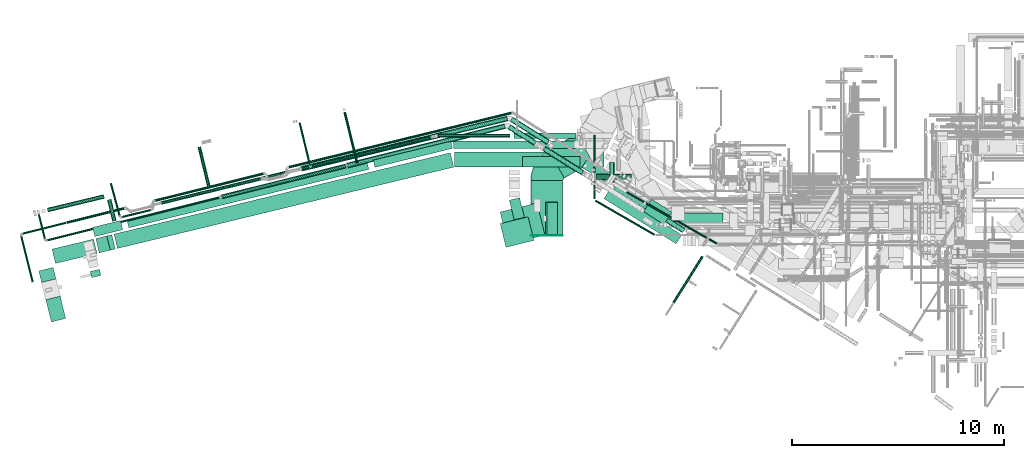
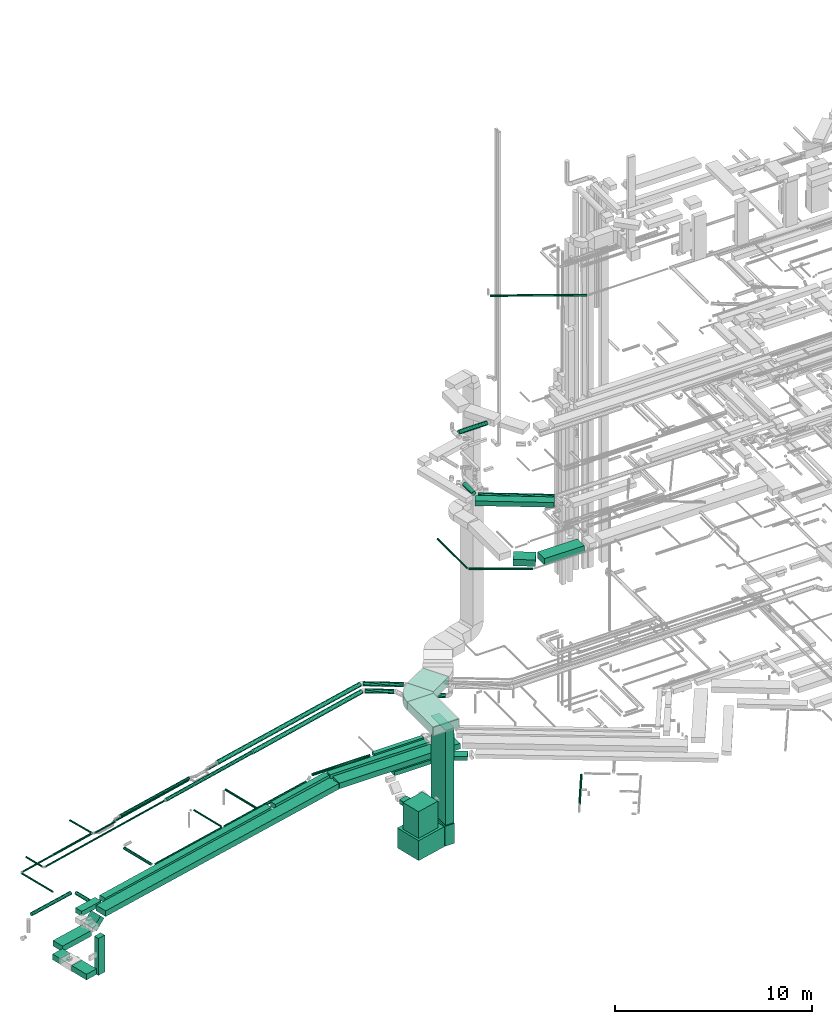
# One storey, part 22 of 337: 55 flow segments, 4 flow fittings.
"""IFC2X3 building model written with IfcOpenShell, lengths in millimetres."""

from ifc_helpers import new_model, entity, si_unit, converted_unit, derived_unit, direction, frame, frame_2d, origin, origin_2d_with_axis, place, context, subcontext, project, spatial, polyline, circle_curve, parameter, trimmed, segment, composite_curve, rectangle, circle, outline, extrude, source, transform, mapped, material, type_object, type_shapes, element, save


model = new_model("IFC2X3")

# Units and contexts
model_context = context("Model", 3, precision=0.01, world=origin(), true_north=direction((6.12303176911189e-17, 1.0)))
body_context = subcontext(model_context, "Body", "Model", "MODEL_VIEW")
ifc_project = project(units=[si_unit("LENGTHUNIT", "METRE", prefix="MILLI"), si_unit("AREAUNIT", "SQUARE_METRE"), si_unit("VOLUMEUNIT", "CUBIC_METRE"), converted_unit("PLANEANGLEUNIT", "DEGREE", entity("IfcRatioMeasure", 0.0174532925199433), si_unit("PLANEANGLEUNIT", "RADIAN"), dimensions=[0, 0, 0, 0, 0, 0, 0]), si_unit("MASSUNIT", "GRAM", prefix="KILO"), derived_unit("MASSDENSITYUNIT", [(si_unit("MASSUNIT", "GRAM", prefix="KILO"), 1), (si_unit("LENGTHUNIT", "METRE"), -3)]), derived_unit("MOMENTOFINERTIAUNIT", [(si_unit("LENGTHUNIT", "METRE"), 4)]), si_unit("TIMEUNIT", "SECOND"), si_unit("FREQUENCYUNIT", "HERTZ"), si_unit("THERMODYNAMICTEMPERATUREUNIT", "DEGREE_CELSIUS"), derived_unit("THERMALTRANSMITTANCEUNIT", [(si_unit("MASSUNIT", "GRAM", prefix="KILO"), 1), (si_unit("THERMODYNAMICTEMPERATUREUNIT", "KELVIN"), -1), (si_unit("TIMEUNIT", "SECOND"), -3)]), derived_unit("VOLUMETRICFLOWRATEUNIT", [(si_unit("LENGTHUNIT", "METRE"), 3), (si_unit("TIMEUNIT", "SECOND"), -1)]), derived_unit("MASSFLOWRATEUNIT", [(si_unit("MASSUNIT", "GRAM", prefix="KILO"), 1), (si_unit("TIMEUNIT", "SECOND"), -1)]), derived_unit("ROTATIONALFREQUENCYUNIT", [(si_unit("TIMEUNIT", "SECOND"), -1)]), si_unit("ELECTRICCURRENTUNIT", "AMPERE"), si_unit("ELECTRICVOLTAGEUNIT", "VOLT"), si_unit("POWERUNIT", "WATT"), si_unit("FORCEUNIT", "NEWTON", prefix="KILO"), si_unit("ILLUMINANCEUNIT", "LUX"), si_unit("LUMINOUSFLUXUNIT", "LUMEN"), si_unit("LUMINOUSINTENSITYUNIT", "CANDELA"), derived_unit("USERDEFINED", [(si_unit("MASSUNIT", "GRAM", prefix="KILO"), -1), (si_unit("LENGTHUNIT", "METRE"), -2), (si_unit("TIMEUNIT", "SECOND"), 3), (si_unit("LUMINOUSFLUXUNIT", "LUMEN"), 1)]), derived_unit("LINEARVELOCITYUNIT", [(si_unit("LENGTHUNIT", "METRE"), 1), (si_unit("TIMEUNIT", "SECOND"), -1)]), si_unit("PRESSUREUNIT", "PASCAL"), derived_unit("USERDEFINED", [(si_unit("LENGTHUNIT", "METRE"), -2), (si_unit("MASSUNIT", "GRAM", prefix="KILO"), 1), (si_unit("TIMEUNIT", "SECOND"), -2)]), derived_unit("LINEARFORCEUNIT", [(si_unit("MASSUNIT", "GRAM", prefix="KILO"), 1), (si_unit("LENGTHUNIT", "METRE"), 1), (si_unit("TIMEUNIT", "SECOND"), -2), (si_unit("LENGTHUNIT", "METRE"), -1)]), derived_unit("PLANARFORCEUNIT", [(si_unit("MASSUNIT", "GRAM", prefix="KILO"), 1), (si_unit("LENGTHUNIT", "METRE"), 1), (si_unit("TIMEUNIT", "SECOND"), -2), (si_unit("LENGTHUNIT", "METRE"), -2)])], contexts=[model_context])

# Site, building, storey
site_placement = place(None, origin())
site = spatial("IfcSite", under=ifc_project, at=site_placement, CompositionType="ELEMENT")
building_placement = place(site_placement, origin())
building = spatial("IfcBuilding", under=site, at=building_placement, CompositionType="ELEMENT")
storey_placement = place(building_placement, origin())
storey = spatial("IfcBuildingStorey", under=building, at=storey_placement, CompositionType="ELEMENT", Elevation=0.0)

# Flow segments
duct_segment_type_1 = type_object("IfcDuctSegmentType", PredefinedType="NOTDEFINED")
flow_segment_1_placement = place(storey_placement, frame((-24658.62, 6458.64, -1525.0)))
element("IfcFlowSegment", 1, at=flow_segment_1_placement, inside=storey, type_object=duct_segment_type_1, context=body_context, shape_type="SweptSolid", body=[
    extrude(rectangle(XDim=1079.40182496234, YDim=700.000000000001, at=origin_2d_with_axis()), frame((468.95, 607.76, 0.0), z_axis=(0.0, 0.0, 1.0), x_axis=(-0.239234929345687, 0.970961713241549, 0.0)), (0.0, 0.0, 1.0), 350.0),
])
flow_segment_2_placement = place(storey_placement, frame((-24994.78, 8323.76, -1525.0)))
element("IfcFlowSegment", 2, at=flow_segment_2_placement, inside=storey, type_object=duct_segment_type_1, context=body_context, shape_type="SweptSolid", body=[
    extrude(rectangle(XDim=563.648083324207, YDim=699.999999999999, at=origin_2d_with_axis()), frame((407.26, 357.37, 0.0), z_axis=(0.0, 0.0, 1.0), x_axis=(-0.239240175396018, 0.970960420653943, 0.0)), (0.0, 0.0, 1.0), 350.0),
])
flow_segment_3_placement = place(storey_placement, frame((-21439.78, 9928.88, -800.0)))
element("IfcFlowSegment", 3, at=flow_segment_3_placement, inside=storey, type_object=duct_segment_type_1, context=body_context, shape_type="SweptSolid", body=[
    extrude(rectangle(XDim=16341.481014958, YDim=699.999999999999, at=origin_2d_with_axis()), frame((8023.96, 2261.37, 0.0), z_axis=(0.0, 0.0, 1.0), x_axis=(0.971963923974013, 0.235130028905367, 0.0)), (0.0, 0.0, 1.0), 350.0),
])
flow_segment_4_placement = place(storey_placement, frame((-5356.59, 13775.46, -800.0)))
element("IfcFlowSegment", 4, at=flow_segment_4_placement, inside=storey, type_object=duct_segment_type_1, context=body_context, shape_type="SweptSolid", body=[
    extrude(rectangle(XDim=7058.84355228445, YDim=700.000000000001, at=origin_2d_with_axis()), frame((3529.42, 350.0, 0.0), z_axis=(0.0, 0.0, 1.0), x_axis=(-1.0, 0.0, 0.0)), (0.0, 0.0, 1.0), 350.0),
])
flow_segment_5_placement = place(storey_placement, frame((-3207.37, 10132.86, -3924.0)))
element("IfcFlowSegment", 5, at=flow_segment_5_placement, inside=storey, type_object=duct_segment_type_1, context=body_context, shape_type="SweptSolid", body=[
    extrude(rectangle(XDim=1798.03044704214, YDim=1568.0, at=origin_2d_with_axis()), frame((1059.56, 975.17, 0.0), z_axis=(0.0, 0.0, 1.0), x_axis=(0.971358698487876, 0.237617926242823, 0.0)), (0.0, 0.0, 1.0), 1238.0),
])
flow_segment_6_placement = place(storey_placement, frame((-1052.61, 10564.4, -3924.0)))
element("IfcFlowSegment", 6, at=flow_segment_6_placement, inside=storey, type_object=duct_segment_type_1, context=body_context, shape_type="SweptSolid", body=[
    extrude(rectangle(XDim=567.420212627502, YDim=1568.0, at=origin_2d_with_axis()), frame((283.71, 784.0, 0.0)), (0.0, 0.0, 1.0), 1238.0),
])
flow_segment_7_placement = place(storey_placement, frame((-22566.41, 8552.28, -3185.0)))
element("IfcFlowSegment", 7, at=flow_segment_7_placement, inside=storey, type_object=duct_segment_type_1, context=body_context, shape_type="SweptSolid", body=[
    extrude(rectangle(XDim=300.000000000002, YDim=450.000000000001, at=origin_2d_with_axis()), frame((254.08, 198.94, 0.0), z_axis=(1.30834769717266e-06, -5.37909916892362e-06, 1.0), x_axis=(-0.236337623155953, 0.97167099774067, 5.5359264415102e-06)), (0.0, 0.0, 1.0), 2284.95162721462),
])
flow_segment_8_placement = place(storey_placement, frame((-20835.17, 10902.27, -750.0)))
element("IfcFlowSegment", 8, at=flow_segment_8_placement, inside=storey, type_object=duct_segment_type_1, context=body_context, shape_type="SweptSolid", body=[
    extrude(rectangle(XDim=11666.6777760886, YDim=399.999999999999, at=origin_2d_with_axis()), frame((5714.8, 1575.61, 0.0), z_axis=(0.0, 0.0, 1.0), x_axis=(0.971559912665503, 0.236793868377963, 0.0)), (0.0, 0.0, 1.0), 300.0),
])
flow_segment_9_placement = place(storey_placement, frame((-9202.9, 13760.19, -750.0)))
element("IfcFlowSegment", 9, at=flow_segment_9_placement, inside=storey, type_object=duct_segment_type_1, context=body_context, shape_type="SweptSolid", body=[
    extrude(rectangle(XDim=3774.44741521228, YDim=350.0, at=origin_2d_with_axis()), frame((1874.99, 616.91, 0.0), z_axis=(0.0, 0.0, 1.0), x_axis=(0.9715599126655, 0.236793868377977, 0.0)), (0.0, 0.0, 1.0), 300.0),
])
flow_segment_10_placement = place(storey_placement, frame((-5417.41, 14658.23, -750.0)))
element("IfcFlowSegment", 10, at=flow_segment_10_placement, inside=storey, type_object=duct_segment_type_1, context=body_context, shape_type="SweptSolid", body=[
    extrude(rectangle(XDim=5802.50714283817, YDim=350.000000000001, at=origin_2d_with_axis()), frame((2901.25, 175.0, 0.0), z_axis=(0.0, 0.0, 1.0), x_axis=(-1.0, 0.0, 0.0)), (0.0, 0.0, 1.0), 300.0),
])
flow_segment_11_placement = place(storey_placement, frame((-22455.84, 10491.91, -750.0)))
element("IfcFlowSegment", 11, at=flow_segment_11_placement, inside=storey, type_object=duct_segment_type_1, context=body_context, shape_type="SweptSolid", body=[
    extrude(rectangle(XDim=1360.43438674366, YDim=450.0, at=origin_2d_with_axis()), frame((714.09, 379.09, 0.0), z_axis=(0.0, 0.0, 1.0), x_axis=(-0.971787577071847, -0.235857806843082, 0.0)), (0.0, 0.0, 1.0), 300.0),
])
flow_segment_12_placement = place(storey_placement, frame((-3202.7, 9983.66, -2418.37)))
element("IfcFlowSegment", 12, at=flow_segment_12_placement, inside=storey, type_object=duct_segment_type_1, context=body_context, shape_type="SweptSolid", body=[
    extrude(rectangle(XDim=1360.0, YDim=1150.0, at=origin_2d_with_axis()), frame((797.54, 720.62, 0.0), z_axis=(0.0, 0.0, 1.0), x_axis=(-0.971126038182249, -0.238567009379859, 0.0)), (0.0, 0.0, 1.0), 1650.0),
])
flow_segment_13_placement = place(storey_placement, frame((-2770.45, 11283.24, -1675.0)))
element("IfcFlowSegment", 13, at=flow_segment_13_placement, inside=storey, type_object=duct_segment_type_1, context=body_context, shape_type="SweptSolid", body=[
    extrude(rectangle(XDim=955.574923264787, YDim=500.0, at=origin_2d_with_axis()), frame((356.77, 523.63, 0.0), z_axis=(0.0, 0.0, 1.0), x_axis=(-0.238567009379864, 0.971126038182248, 0.0)), (0.0, 0.0, 1.0), 250.0),
])
flow_segment_14_placement = place(storey_placement, frame((-2139.22, 13771.58, -1125.0)))
element("IfcFlowSegment", 14, at=flow_segment_14_placement, inside=storey, type_object=duct_segment_type_1, context=body_context, shape_type="SweptSolid", body=[
    extrude(rectangle(XDim=2716.99429169592, YDim=499.999999999999, at=origin_2d_with_axis()), frame((1358.5, 250.0, 0.01), z_axis=(-6.17522343880966e-06, 0.0, 1.0), x_axis=(-1.0, 0.0, -6.17522343880966e-06)), (0.0, 0.0, 1.0), 250.0),
])
flow_segment_15_placement = place(storey_placement, frame((656.53, 13086.01, -1124.98)))
element("IfcFlowSegment", 15, at=flow_segment_15_placement, inside=storey, type_object=duct_segment_type_1, context=body_context, shape_type="SweptSolid", body=[
    extrude(rectangle(XDim=1263.23389062571, YDim=500.0, at=origin_2d_with_axis()), frame((668.82, 544.38, 0.0), z_axis=(0.0, 0.0, 1.0), x_axis=(0.851088816343194, -0.525021739259948, 0.0)), (0.0, 0.0, 1.0), 250.0),
])
flow_segment_16_placement = place(storey_placement, frame((1699.34, 10148.65, 15150.0)))
element("IfcFlowSegment", 16, at=flow_segment_16_placement, inside=storey, type_object=duct_segment_type_1, context=body_context, shape_type="SweptSolid", body=[
    extrude(rectangle(XDim=4022.35257835515, YDim=499.999999999999, at=origin_2d_with_axis()), frame((1837.4, 1278.98, 0.0), z_axis=(0.0, 0.0, 1.0), x_axis=(0.847641877077064, -0.530568796882433, 0.0)), (0.0, 0.0, 1.0), 300.000000000001),
])
flow_segment_17_placement = place(storey_placement, frame((-985.64, 10598.4, -2666.0)))
element("IfcFlowSegment", 17, at=flow_segment_17_placement, inside=storey, type_object=duct_segment_type_1, context=body_context, shape_type="SweptSolid", body=[
    extrude(rectangle(XDim=500.0, YDim=1500.0, at=origin_2d_with_axis()), frame((250.0, 750.0, 0.0)), (0.0, 0.0, 1.0), 5846.000025),
])
flow_segment_18_placement = place(storey_placement, frame((3572.05, 11054.35, 11150.0)))
element("IfcFlowSegment", 18, at=flow_segment_18_placement, inside=storey, type_object=duct_segment_type_1, context=body_context, shape_type="SweptSolid", body=[
    extrude(rectangle(XDim=1137.92404548973, YDim=700.0, at=origin_2d_with_axis()), frame((667.8, 603.41, 0.0), z_axis=(0.0, 0.0, 1.0), x_axis=(-0.83867056794542, 0.544639035015034, 0.0)), (0.0, 0.0, 1.0), 400.0),
])
flow_segment_19_placement = place(storey_placement, frame((4989.34, 10917.22, 11150.0)))
element("IfcFlowSegment", 19, at=flow_segment_19_placement, inside=storey, type_object=duct_segment_type_1, context=body_context, shape_type="SweptSolid", body=[
    extrude(rectangle(XDim=2335.00000000022, YDim=700.000000000001, at=origin_2d_with_axis()), frame((1167.5, 350.0, 0.0)), (0.0, 0.0, 1.0), 400.0),
])
flow_segment_20_placement = place(storey_placement, frame((-924.92, 13265.54, 3200.0)))
element("IfcFlowSegment", 20, at=flow_segment_20_placement, inside=storey, type_object=duct_segment_type_1, context=body_context, shape_type="SweptSolid", body=[
    extrude(rectangle(XDim=1539.23048454135, YDim=1500.0, at=origin_2d_with_axis()), frame((1041.51, 1034.33, 0.0), z_axis=(0.0, 0.0, 1.0), x_axis=(-0.866025403784442, -0.499999999999995, 0.0)), (0.0, 0.0, 1.0), 500.0),
])
flow_segment_21_placement = place(storey_placement, frame((-1749.92, 10553.38, 3200.0)))
element("IfcFlowSegment", 21, at=flow_segment_21_placement, inside=storey, type_object=duct_segment_type_1, context=body_context, shape_type="SweptSolid", body=[
    extrude(rectangle(XDim=2582.25764801308, YDim=1500.0, at=origin_2d_with_axis()), frame((750.0, 1291.13, 0.0), z_axis=(0.0, 0.0, 1.0), x_axis=(0.0, -1.0, 0.0)), (0.0, 0.0, 1.0), 500.0),
])
flow_segment_22_placement = place(storey_placement, frame((-2540.29, 15124.67, -650.0)))
element("IfcFlowSegment", 22, at=flow_segment_22_placement, inside=storey, type_object=duct_segment_type_1, context=body_context, shape_type="SweptSolid", body=[
    extrude(rectangle(XDim=2893.88933525546, YDim=249.999999999999, at=origin_2d_with_axis()), frame((1446.94, 125.0, 0.0)), (0.0, 0.0, 1.0), 200.0),
])
flow_segment_23_placement = place(storey_placement, frame((-24369.32, 9220.18, -1525.0)))
element("IfcFlowSegment", 23, at=flow_segment_23_placement, inside=storey, type_object=duct_segment_type_1, context=body_context, shape_type="SweptSolid", body=[
    extrude(rectangle(XDim=2019.81232553969, YDim=700.000000000001, at=origin_2d_with_axis()), frame((1063.89, 577.65, 0.0), z_axis=(0.0, 0.0, 1.0), x_axis=(0.971963923974013, 0.235130028905366, 0.0)), (0.0, 0.0, 1.0), 350.0),
])
flow_segment_24_placement = place(storey_placement, frame((-22303.05, 9720.04, -1378.55)))
element("IfcFlowSegment", 24, at=flow_segment_24_placement, inside=storey, type_object=duct_segment_type_1, context=body_context, shape_type="SweptSolid", body=[
    extrude(rectangle(XDim=349.999999999999, YDim=699.999999999998, at=frame_2d((0.0, 0.0), x_axis=(0.0, 1.0))), frame((202.57, 369.28, 123.74), z_axis=(0.6872822817107, 0.166262037899578, 0.707106781186557), x_axis=(-0.235130028905373, 0.971963923974012, 0.0)), (0.0, 0.0, 1.0), 756.066017177978),
])
duct_segment_type_2 = type_object("IfcDuctSegmentType", PredefinedType="NOTDEFINED")
flow_segment_25_placement = place(storey_placement, frame((-10607.12, 13946.1, -664.1)))
element("IfcFlowSegment", 25, at=flow_segment_25_placement, inside=storey, type_object=duct_segment_type_2, context=body_context, shape_type="SweptSolid", body=[
    extrude(circle(Radius=62.5, at=origin_2d_with_axis()), frame((648.98, 16.39, 64.1), z_axis=(-0.236793973687132, 0.971559886998973, 0.0), x_axis=(0.971559886998973, 0.236793973687132, 0.0)), (0.0, 0.0, 1.0), 2477.50718281716),
])
flow_segment_26_placement = place(storey_placement, frame((-21766.38, 11194.03, -701.6)))
element("IfcFlowSegment", 26, at=flow_segment_26_placement, inside=storey, type_object=duct_segment_type_2, context=body_context, shape_type="SweptSolid", body=[
    extrude(circle(Radius=100.0, at=origin_2d_with_axis()), frame((346.64, 25.24, 101.6), z_axis=(-0.236415528046378, 0.971652045795486, 0.0), x_axis=(0.971652045795486, 0.236415528046378, 0.0)), (0.0, 0.0, 1.0), 1048.50197696042),
])
flow_segment_27_placement = place(storey_placement, frame((-24603.89, 11645.61, -701.6)))
element("IfcFlowSegment", 27, at=flow_segment_27_placement, inside=storey, type_object=duct_segment_type_2, context=body_context, shape_type="SweptSolid", body=[
    extrude(circle(Radius=100.0, at=origin_2d_with_axis()), frame((24.93, 98.83, 101.6), z_axis=(0.972394174605969, 0.233344314677639, 0.0), x_axis=(-0.233344314677639, 0.972394174605969, 0.0)), (0.0, 0.0, 1.0), 2746.4176011274),
])
flow_segment_28_placement = place(storey_placement, frame((-17494.34, 12781.23, -901.6)))
element("IfcFlowSegment", 28, at=flow_segment_28_placement, inside=storey, type_object=duct_segment_type_2, context=body_context, shape_type="SweptSolid", body=[
    extrude(circle(Radius=80.0, at=origin_2d_with_axis()), frame((546.4, 20.46, 81.6), z_axis=(-0.235857806843071, 0.97178757707185, 0.0), x_axis=(0.97178757707185, 0.235857806843071, 0.0)), (0.0, 0.0, 1.0), 1980.2662334788),
])
flow_segment_29_placement = place(storey_placement, frame((-12092.48, 13741.66, -901.63)))
element("IfcFlowSegment", 29, at=flow_segment_29_placement, inside=storey, type_object=duct_segment_type_2, context=body_context, shape_type="SweptSolid", body=[
    extrude(circle(Radius=80.0, at=origin_2d_with_axis()), frame((20.47, 79.34, 81.63), z_axis=(0.971767239298817, 0.235941587220887, -6.72635830897582e-06), x_axis=(-0.235941587226224, 0.971767239320801, 0.0)), (0.0, 0.0, 1.0), 5718.88265517336),
])
flow_segment_30_placement = place(storey_placement, frame((-16775.17, 12604.61, -901.6)))
element("IfcFlowSegment", 30, at=flow_segment_30_placement, inside=storey, type_object=duct_segment_type_2, context=body_context, shape_type="SweptSolid", body=[
    extrude(circle(Radius=80.0, at=origin_2d_with_axis()), frame((20.47, 79.34, 81.6), z_axis=(0.971762267191903, 0.235962064879195, 0.0), x_axis=(0.235962064879195, -0.971762267191903, 0.0)), (0.0, 0.0, 1.0), 4618.75789261243),
])
flow_segment_31_placement = place(storey_placement, frame((-12726.08, 13910.29, -871.6)))
element("IfcFlowSegment", 31, at=flow_segment_31_placement, inside=storey, type_object=duct_segment_type_2, context=body_context, shape_type="SweptSolid", body=[
    extrude(circle(Radius=50.0, at=origin_2d_with_axis()), frame((50.17, 1965.92, 51.6), z_axis=(0.2368747123819, -0.971540205361565, 0.0), x_axis=(0.971540205361565, 0.2368747123819, 0.0)), (0.0, 0.0, 1.0), 2009.67341232844),
])
flow_segment_32_placement = place(storey_placement, frame((-25872.72, 8324.53, 3048.4)))
element("IfcFlowSegment", 32, at=flow_segment_32_placement, inside=storey, type_object=duct_segment_type_2, context=body_context, shape_type="SweptSolid", body=[
    extrude(circle(Radius=50.0, at=origin_2d_with_axis()), frame((592.02, 13.69, 51.6), z_axis=(-0.241921895599668, 0.970295726275997, 0.0), x_axis=(-0.970295726275997, -0.241921895599668, 0.0)), (0.0, 0.0, 1.0), 2240.00000000001),
])
flow_segment_33_placement = place(storey_placement, frame((4930.21, 7329.62, -1534.1)))
element("IfcFlowSegment", 33, at=flow_segment_33_placement, inside=storey, type_object=duct_segment_type_2, context=body_context, shape_type="SweptSolid", body=[
    extrude(circle(Radius=62.5, at=origin_2d_with_axis()), frame((54.61, 34.69, 64.1), z_axis=(0.529591024309095, 0.848253114919859, 0.0), x_axis=(-0.848253114919859, 0.529591024309095, 0.0)), (0.0, 0.0, 1.0), 2589.97570347762),
])
flow_segment_34_placement = place(storey_placement, frame((1267.19, 10530.02, 11398.4)))
element("IfcFlowSegment", 34, at=flow_segment_34_placement, inside=storey, type_object=duct_segment_type_2, context=body_context, shape_type="SweptSolid", body=[
    extrude(circle(Radius=50.0, at=origin_2d_with_axis()), frame((26.6, 1659.76, 51.6), z_axis=(0.866025403784436, -0.500000000000005, 0.0), x_axis=(0.500000000000005, 0.866025403784436, 0.0)), (0.0, 0.0, 1.0), 3229.72631225999),
])
flow_segment_35_placement = place(storey_placement, frame((1192.19, 12276.38, 11398.4)))
element("IfcFlowSegment", 35, at=flow_segment_35_placement, inside=storey, type_object=duct_segment_type_2, context=body_context, shape_type="SweptSolid", body=[
    extrude(circle(Radius=50.0, at=origin_2d_with_axis()), frame((51.6, 0.0, 51.6), z_axis=(0.0, 1.0, 0.0), x_axis=(1.0, 0.0, 0.0)), (0.0, 0.0, 1.0), 3005.13684387001),
])
flow_segment_36_placement = place(storey_placement, frame((-23696.94, 11086.66, 3035.9)))
element("IfcFlowSegment", 36, at=flow_segment_36_placement, inside=storey, type_object=duct_segment_type_2, context=body_context, shape_type="SweptSolid", body=[
    extrude(circle(Radius=62.5, at=origin_2d_with_axis()), frame((16.72, 62.24, 64.1), z_axis=(0.970295726275998, 0.241921895599663, 0.0), x_axis=(0.241921895599663, -0.970295726275998, 0.0)), (0.0, 0.0, 1.0), 2808.22330470342),
])
flow_segment_37_placement = place(storey_placement, frame((-19514.53, 12127.53, 3035.9)))
element("IfcFlowSegment", 37, at=flow_segment_37_placement, inside=storey, type_object=duct_segment_type_2, context=body_context, shape_type="SweptSolid", body=[
    extrude(circle(Radius=62.5, at=origin_2d_with_axis()), frame((16.72, 62.24, 64.1), z_axis=(0.970295726275998, 0.241921895599661, 0.0), x_axis=(0.241921895599661, -0.970295726275998, 0.0)), (0.0, 0.0, 1.0), 5263.2233047034),
])
flow_segment_38_placement = place(storey_placement, frame((-25763.46, 10582.8, 3048.4)))
element("IfcFlowSegment", 38, at=flow_segment_38_placement, inside=storey, type_object=duct_segment_type_2, context=body_context, shape_type="SweptSolid", body=[
    extrude(circle(Radius=50.0, at=origin_2d_with_axis()), frame((13.69, 50.11, 51.6), z_axis=(0.970295726275998, 0.241921895599663, 0.0), x_axis=(0.241921895599663, -0.970295726275998, 0.0)), (0.0, 0.0, 1.0), 2107.90251161266),
])
flow_segment_39_placement = place(storey_placement, frame((-25048.37, 10377.65, 3158.4)))
element("IfcFlowSegment", 39, at=flow_segment_39_placement, inside=storey, type_object=duct_segment_type_2, context=body_context, shape_type="SweptSolid", body=[
    extrude(circle(Radius=50.0, at=origin_2d_with_axis()), frame((50.11, 1180.4, 51.6), z_axis=(0.24192189559964, -0.970295726276003, 0.0), x_axis=(-0.970295726276003, -0.24192189559964, 0.0)), (0.0, 0.0, 1.0), 1202.4257393157),
])
flow_segment_40_placement = place(storey_placement, frame((-10466.56, 13723.96, 3083.4)))
element("IfcFlowSegment", 40, at=flow_segment_40_placement, inside=storey, type_object=duct_segment_type_2, context=body_context, shape_type="SweptSolid", body=[
    extrude(circle(Radius=125.0, at=origin_2d_with_axis()), frame((31.84, 122.88, 126.6), z_axis=(0.970295726275998, 0.241921895599662, 0.0), x_axis=(0.241921895599662, -0.970295726275998, 0.0)), (0.0, 0.0, 1.0), 7691.57762457888),
])
flow_segment_41_placement = place(storey_placement, frame((-24599.83, 10268.39, 3158.4)))
element("IfcFlowSegment", 41, at=flow_segment_41_placement, inside=storey, type_object=duct_segment_type_2, context=body_context, shape_type="SweptSolid", body=[
    extrude(circle(Radius=50.0, at=origin_2d_with_axis()), frame((13.69, 50.11, 51.6), z_axis=(0.970295726275998, 0.241921895599662, 0.0), x_axis=(0.241921895599662, -0.970295726275998, 0.0)), (0.0, 0.0, 1.0), 8372.0000000001),
])
flow_segment_42_placement = place(storey_placement, frame((-16391.58, 12269.44, 3108.4)))
element("IfcFlowSegment", 42, at=flow_segment_42_placement, inside=storey, type_object=duct_segment_type_2, context=body_context, shape_type="SweptSolid", body=[
    extrude(circle(Radius=100.0, at=origin_2d_with_axis()), frame((25.79, 98.62, 101.6), z_axis=(0.970295726275998, 0.241921895599662, 0.0), x_axis=(-0.241921895599662, 0.970295726275998, 0.0)), (0.0, 0.0, 1.0), 6062.64624835209),
])
flow_segment_43_placement = place(storey_placement, frame((-2846.49, 14792.42, 3083.4)))
element("IfcFlowSegment", 43, at=flow_segment_43_placement, inside=storey, type_object=duct_segment_type_2, context=body_context, shape_type="SweptSolid", body=[
    extrude(circle(Radius=125.0, at=origin_2d_with_axis()), frame((1311.35, 107.6, 126.6), z_axis=(-0.848052743777571, 0.52991182641203, 0.0), x_axis=(-0.52991182641203, -0.848052743777571, 0.0)), (0.0, 0.0, 1.0), 1466.31985834062),
])
flow_segment_44_placement = place(storey_placement, frame((-1191.01, 13401.37, 2883.4)))
element("IfcFlowSegment", 44, at=flow_segment_44_placement, inside=storey, type_object=duct_segment_type_2, context=body_context, shape_type="SweptSolid", body=[
    extrude(circle(Radius=125.0, at=origin_2d_with_axis()), frame((1882.06, 107.6, 126.6), z_axis=(-0.848052743777572, 0.529911826412029, 0.0), x_axis=(-0.529911826412029, -0.848052743777572, 0.0)), (0.0, 0.0, 1.0), 2139.28773385407),
])
flow_segment_45_placement = place(storey_placement, frame((-12609.81, 13572.28, 3273.4)))
element("IfcFlowSegment", 45, at=flow_segment_45_placement, inside=storey, type_object=duct_segment_type_2, context=body_context, shape_type="SweptSolid", body=[
    extrude(circle(Radius=125.0, at=origin_2d_with_axis()), frame((31.2, 123.04, 126.6), z_axis=(0.971552058141474, 0.236826092990331, 0.0), x_axis=(0.236826092990331, -0.971552058141474, 0.0)), (0.0, 0.0, 1.0), 9999.61684811951),
])
flow_segment_46_placement = place(storey_placement, frame((-2739.61, 14838.07, 3273.4)))
element("IfcFlowSegment", 46, at=flow_segment_46_placement, inside=storey, type_object=duct_segment_type_2, context=body_context, shape_type="SweptSolid", body=[
    extrude(circle(Radius=125.0, at=origin_2d_with_axis()), frame((1807.33, 107.6, 126.6), z_axis=(-0.848052743777583, 0.52991182641201, 0.0), x_axis=(-0.52991182641201, -0.848052743777583, 0.0)), (0.0, 0.0, 1.0), 2051.1627711614),
])
flow_segment_47_placement = place(storey_placement, frame((-19226.68, 12000.47, 3318.4)))
element("IfcFlowSegment", 47, at=flow_segment_47_placement, inside=storey, type_object=duct_segment_type_2, context=body_context, shape_type="SweptSolid", body=[
    extrude(circle(Radius=80.0, at=origin_2d_with_axis()), frame((20.54, 79.32, 81.6), z_axis=(0.971552058141472, 0.236826092990341, 0.0), x_axis=(-0.236826092990341, 0.971552058141472, 0.0)), (0.0, 0.0, 1.0), 4846.30636332887),
])
flow_segment_48_placement = place(storey_placement, frame((-21074.05, 11365.11, 3348.4)))
element("IfcFlowSegment", 48, at=flow_segment_48_placement, inside=storey, type_object=duct_segment_type_2, context=body_context, shape_type="SweptSolid", body=[
    extrude(circle(Radius=50.0, at=origin_2d_with_axis()), frame((13.44, 50.17, 51.6), z_axis=(0.971552058141476, 0.236826092990327, 0.0), x_axis=(-0.236826092990327, 0.971552058141476, 0.0)), (0.0, 0.0, 1.0), 1409.0027849174),
])
flow_segment_49_placement = place(storey_placement, frame((-21640.29, 11472.02, 3348.4)))
element("IfcFlowSegment", 49, at=flow_segment_49_placement, inside=storey, type_object=duct_segment_type_2, context=body_context, shape_type="SweptSolid", body=[
    extrude(circle(Radius=50.0, at=origin_2d_with_axis()), frame((49.89, 1542.84, 51.6), z_axis=(0.258819045102516, -0.96592582628907, 0.0), x_axis=(0.96592582628907, 0.258819045102516, 0.0)), (0.0, 0.0, 1.0), 1582.21651771374),
])
flow_segment_50_placement = place(storey_placement, frame((2126.26, 10665.02, 15198.4)))
element("IfcFlowSegment", 50, at=flow_segment_50_placement, inside=storey, type_object=duct_segment_type_2, context=body_context, shape_type="SweptSolid", body=[
    extrude(circle(Radius=125.0, at=origin_2d_with_axis()), frame((3348.76, 107.6, 126.6), z_axis=(-0.848052743777569, 0.529911826412033, 0.0), x_axis=(-0.529911826412033, -0.848052743777569, 0.0)), (0.0, 0.0, 1.0), 3868.77360094312),
])
flow_segment_51_placement = place(storey_placement, frame((1332.59, 13189.35, 19073.4)))
element("IfcFlowSegment", 51, at=flow_segment_51_placement, inside=storey, type_object=duct_segment_type_2, context=body_context, shape_type="SweptSolid", body=[
    extrude(circle(Radius=125.0, at=origin_2d_with_axis()), frame((0.0, 126.6, 126.6), z_axis=(1.0, 0.0, 0.0), x_axis=(0.0, 1.0, 0.0)), (0.0, 0.0, 1.0), 1657.53796295655),
])
flow_segment_52_placement = place(storey_placement, frame((1949.98, 13034.74, 15198.4)))
element("IfcFlowSegment", 52, at=flow_segment_52_placement, inside=storey, type_object=duct_segment_type_2, context=body_context, shape_type="SweptSolid", body=[
    extrude(circle(Radius=125.0, at=origin_2d_with_axis()), frame((126.6, 0.0, 126.6), z_axis=(0.0, 1.0, 0.0), x_axis=(1.0, 0.0, 0.0)), (0.0, 0.0, 1.0), 955.981845093098),
])
flow_segment_53_placement = place(storey_placement, frame((2739.92, 10115.23, 27548.4)))
element("IfcFlowSegment", 53, at=flow_segment_53_placement, inside=storey, type_object=duct_segment_type_2, context=body_context, shape_type="SweptSolid", body=[
    extrude(circle(Radius=50.0, at=origin_2d_with_axis()), frame((26.36, 2476.57, 51.6), z_axis=(0.868682802297453, -0.495368740427416, 0.0), x_axis=(0.495368740427416, 0.868682802297453, 0.0)), (0.0, 0.0, 1.0), 4908.55638524145),
])
flow_segment_54_placement = place(storey_placement, frame((-13194.88, 13707.51, 3035.9)))
element("IfcFlowSegment", 54, at=flow_segment_54_placement, inside=storey, type_object=duct_segment_type_2, context=body_context, shape_type="SweptSolid", body=[
    extrude(circle(Radius=62.5, at=origin_2d_with_axis()), frame((16.4, 62.32, 64.1), z_axis=(0.971552058141472, 0.236826092990342, 0.0), x_axis=(-0.236826092990342, 0.971552058141472, 0.0)), (0.0, 0.0, 1.0), 10823.2558638566),
])
flow_segment_55_placement = place(storey_placement, frame((-6118.85, 15168.08, -631.6)))
element("IfcFlowSegment", 55, at=flow_segment_55_placement, inside=storey, type_object=duct_segment_type_2, context=body_context, shape_type="SweptSolid", body=[
    extrude(circle(Radius=80.0, at=origin_2d_with_axis()), frame((0.0, 81.6, 81.61), z_axis=(1.0, 0.0, -5.24035917768441e-06), x_axis=(0.0, -1.0, 0.0)), (0.0, 0.0, 1.0), 3378.5628744395),
])

# Flow fittings
ifc_material = material()
duct_fitting_type_1 = type_object("IfcDuctFittingType", PredefinedType="NOTDEFINED", material=ifc_material)
shared_shape_1 = source(origin(), body_context, "Body", "SweptSolid", [
    extrude(rectangle(XDim=24.9999999999999, YDim=1500.0, at=origin_2d_with_axis()), frame((12.5, 0.0, -250.0)), (0.0, 0.0, 1.0), 500.0),
])
type_shapes(duct_fitting_type_1, [shared_shape_1])
flow_fitting_1_placement = place(storey_placement, frame((-999.92, 10553.38, 3450.0), z_axis=(0.0, 0.0, 1.0), x_axis=(0.0, -1.0, 0.0)))
element("IfcFlowFitting", 56, at=flow_fitting_1_placement, inside=storey, type_object=duct_fitting_type_1, material=ifc_material, context=body_context, shape_type="MappedRepresentation", body=[
    mapped(shared_shape_1, transform((0.0, 0.0, 0.0), scale=1.0)),
])
duct_fitting_type_2 = type_object("IfcDuctFittingType", PredefinedType="NOTDEFINED", material=ifc_material)
shared_shape_2 = source(origin(), body_context, "Body", "SweptSolid", [
    extrude(rectangle(XDim=1500.0, YDim=26.0960000000022, at=origin_2d_with_axis()), frame((6.95, 0.0, -250.0), z_axis=(0.0, 0.0, 1.0), x_axis=(0.0, -1.0, 0.0)), (0.0, 0.0, 1.0), 500.0),
])
type_shapes(duct_fitting_type_2, [shared_shape_2])
for number, where, z_axis, x_axis in (
    (57, (-735.64, 11348.4, -2686.0), (1.0, 0.0, 0.0), (0.0, 0.0, 1.0)),
    (58, (-735.64, 11348.4, 3200.0), (1.0, 0.0, 0.0), (0.0, 0.0, -1.0)),
):
    element("IfcFlowFitting", number, at=place(storey_placement, frame(where, z_axis=z_axis, x_axis=x_axis)), inside=storey, type_object=duct_fitting_type_2, material=ifc_material, context=body_context, shape_type="MappedRepresentation", body=[
        mapped(shared_shape_2, transform((0.0, 0.0, 0.0), scale=1.0)),
    ])
duct_fitting_type_3 = type_object("IfcDuctFittingType", PredefinedType="NOTDEFINED", material=ifc_material)
shared_shape_3 = source(origin(), body_context, "Body", "SweptSolid", [
    extrude(outline(composite_curve([segment(polyline([(-975.0, -389.71), (525.0, -389.71)]), True, "CONTINUOUS"), segment(trimmed(circle_curve(frame_2d((675.0, -389.71), x_axis=(-0.5, 0.86602540378442)), 150.0), [parameter(0.0)], [parameter(60.0000000000001)], True, "PARAMETER"), False, "CONTINUOUS"), segment(polyline([(600.0, -259.81), (-150.0, 1039.23)]), True, "CONTINUOUS"), segment(trimmed(circle_curve(frame_2d((675.0, -389.71), x_axis=(-0.5, 0.86602540378442)), 1650.0), [parameter(0.0)], [parameter(60.0000000000001)], True, "PARAMETER"), True, "CONTINUOUS")], self_intersect=False)), frame((-129.9, 225.0, -250.0), z_axis=(0.0, 0.0, 1.0), x_axis=(-0.86602540378444, 0.499999999999998, 0.0)), (0.0, 0.0, 1.0), 500.0),
])
type_shapes(duct_fitting_type_3, [shared_shape_3])
flow_fitting_2_placement = place(storey_placement, frame((-999.92, 13655.25, 3450.0), z_axis=(0.0, 0.0, 1.0), x_axis=(-0.866025403784439, -0.5, 0.0)))
element("IfcFlowFitting", 59, at=flow_fitting_2_placement, inside=storey, type_object=duct_fitting_type_3, material=ifc_material, context=body_context, shape_type="MappedRepresentation", body=[
    mapped(shared_shape_3, transform((0.0, 0.0, 0.0), scale=1.0)),
])

save(model, "model.ifc")
